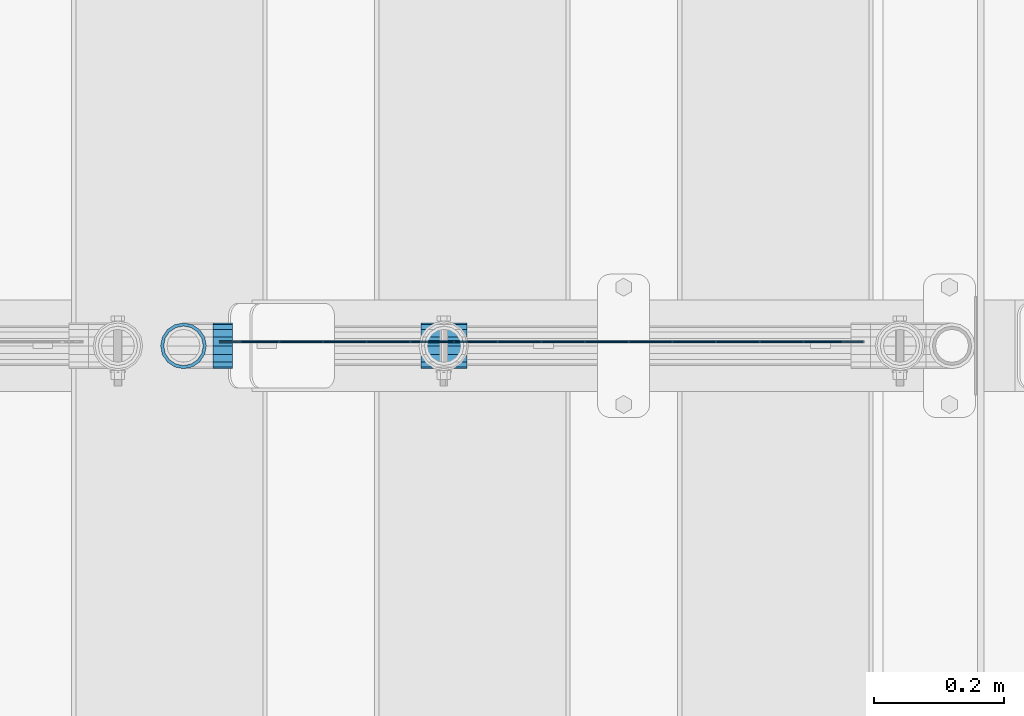
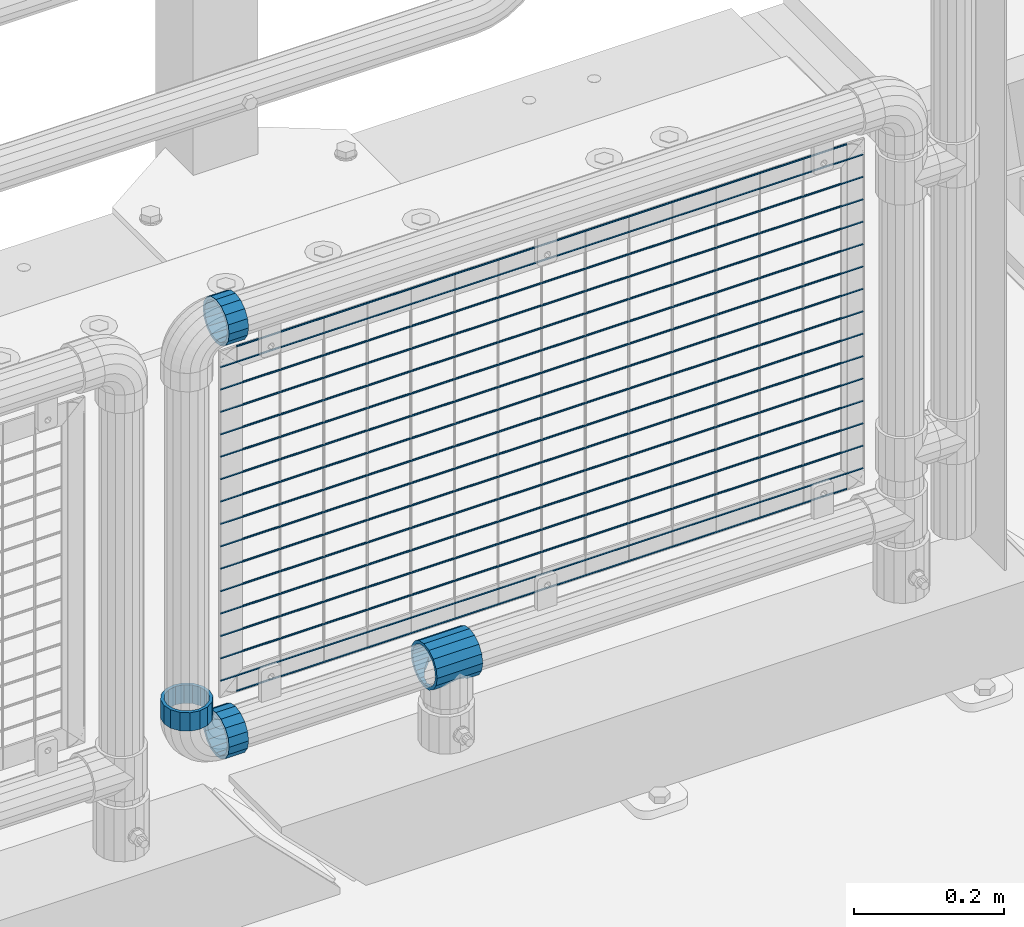
# One storey, part 169 of 257: 21 beams.
"""IFC2X3 building model written with IfcOpenShell, lengths in millimetres."""

from ifc_helpers import new_model, si_unit, frame, origin_with_axes, place, context, subcontext, project, spatial, faceted_brep, material, type_object, element, save


model = new_model("IFC2X3")

# Units and contexts
model_context = context("Model", 3, precision=1e-05, world=origin_with_axes())
body_context = subcontext(model_context, "Body", "Model", "MODEL_VIEW")
ifc_project = project(units=[si_unit("LENGTHUNIT", "METRE", prefix="MILLI"), si_unit("AREAUNIT", "SQUARE_METRE"), si_unit("VOLUMEUNIT", "CUBIC_METRE"), si_unit("MASSUNIT", "GRAM", prefix="KILO"), si_unit("TIMEUNIT", "SECOND"), si_unit("PLANEANGLEUNIT", "RADIAN"), si_unit("SOLIDANGLEUNIT", "STERADIAN"), si_unit("THERMODYNAMICTEMPERATUREUNIT", "DEGREE_CELSIUS"), si_unit("LUMINOUSINTENSITYUNIT", "LUMEN")], contexts=[model_context])

# Site, building, storey
site_placement = place(None, origin_with_axes())
site = spatial("IfcSite", under=ifc_project, at=site_placement, CompositionType="ELEMENT")
building_placement = place(site_placement, origin_with_axes())
building = spatial("IfcBuilding", under=site, at=building_placement, Name="Standard", CompositionType="ELEMENT")
storey_placement = place(building_placement, origin_with_axes())
storey = spatial("IfcBuildingStorey", under=building, at=storey_placement, Name="Undefined", CompositionType="ELEMENT", Elevation=0.0)

# Beams
ifc_material = material(Name="Misc_Undefined")
beam_type_1 = type_object("IfcBeamType", PredefinedType="NOTDEFINED")
beam_1_placement = place(storey_placement, frame((57936.46, 10664.5, 298.169999999999), z_axis=(0.0, 0.0, 1.0), x_axis=(1.0, 0.0, 0.0)))
element("IfcBeam", 1, at=beam_1_placement, inside=storey, type_object=beam_type_1, material=ifc_material, context=body_context, shape_type="Brep", body=[
    faceted_brep([(61.9623795176756, -13.4513226476338, -32.4743655677739), (56.6106908090114, -21.4606908090118, -27.1226768591077), (56.6106908090114, -21.4606908090118, -21.4606908090136), (63.1897438117172, -11.6144421722802, -28.0397438117143), (63.1897438117172, -11.6144421722802, -32.8397438117245), (51.5310424080038, -24.8548033587067, -24.8548033587067), (46.7644421722801, -28.0397438117179, -20.0882031229849), (46.7644421722801, -28.0397438117179, -11.6144421722784), (35.1499999999996, -30.3500000000004, -16.6306603983685), (35.1500000000015, -30.35, 0.0), (23.5355578277191, -28.0397438117179, -20.0882031229849), (23.5355578277191, -28.0397438117179, -11.6144421722784), (13.6893091909879, -21.4606908090118, -27.1226768591077), (13.6893091909879, -21.4606908090118, -21.4606908090136), (18.7689575919987, -24.8548033587067, -24.8548033587067), (7.11025618828205, -11.6144421722802, -32.8397438117245), (7.11025618828205, -11.6144421722802, -28.0397438117143), (8.33762048232484, -13.4513226476338, -32.4743655677739), (4.79999999999961, 0.0, -35.1500000000015), (4.79999999999961, 0.0, -30.3499999999985), (7.11025618828211, 11.6144421722802, -32.8397438117245), (7.11025618828211, 11.6144421722802, -28.0397438117143), (8.3376204823237, 13.4513226476338, -32.4743655677739), (13.6893091909879, 21.4606908090118, -27.1226768591077), (13.6893091909879, 21.4606908090118, -21.4606908090136), (18.7689575919954, 24.8548033587067, -24.8548033587067), (23.5355578277192, 28.0397438117179, -20.0882031229921), (23.5355578277192, 28.0397438117179, -11.6144421722784), (35.1499999999996, 30.3500000000004, -16.6306603983758), (35.1500000000015, 30.35, 0.0), (46.7644421722801, 28.0397438117179, -20.0882031229921), (46.7644421722801, 28.0397438117179, -11.6144421722784), (56.6106908090114, 21.4606908090118, -27.1226768591077), (56.6106908090114, 21.4606908090118, -21.4606908090136), (51.5310424080039, 24.8548033587067, -24.8548033587067), (63.1897438117172, 11.6144421722802, -32.8397438117245), (63.1897438117172, 11.6144421722802, -28.0397438117143), (61.9623795176756, 13.4513226476338, -32.4743655677739), (65.4999999999997, 0.0, -35.1500000000015), (65.4999999999997, 0.0, -30.3499999999985), (0.0, -21.4606908090118, -21.4606908090136), (0.0, -28.0397438117179, -11.6144421722784), (0.0, -11.6144421722802, -28.0397438117143), (0.0, 0.0, -30.3499999999985), (0.0, 11.6144421722802, -28.0397438117143), (0.0, 21.4606908090118, -21.4606908090136), (0.0, 28.0397438117179, -11.6144421722784), (0.0, 30.3500000000004, 0.0), (0.0, 32.4743655677721, -13.4513226476338), (0.0, 35.1499999999996, 0.0), (70.2999999999993, 35.1499999999996, 0.0), (70.2999999999993, 32.4743655677721, -13.4513226476338), (0.0, 32.4743655677721, 13.4513226476338), (70.2999999999993, 32.4743655677721, 13.4513226476338), (0.0, 24.8548033587067, 24.8548033587067), (70.2999999999993, 24.8548033587067, 24.8548033587067), (0.0, 13.4513226476338, 32.4743655677739), (70.2999999999993, 13.4513226476338, 32.4743655677739), (0.0, 0.0, 35.1499999999996), (70.2999999999993, 0.0, 35.1500000000015), (0.0, -13.4513226476338, 32.4743655677739), (70.2999999999993, -13.4513226476338, 32.4743655677739), (0.0, -24.8548033587067, 24.8548033587067), (70.2999999999993, -24.8548033587067, 24.8548033587067), (0.0, -32.4743655677721, 13.4513226476338), (70.2999999999993, -32.4743655677721, 13.4513226476338), (0.0, -35.1499999999996, 0.0), (70.2999999999993, -35.1499999999996, 0.0), (0.0, -32.4743655677721, -13.4513226476338), (70.2999999999993, -32.4743655677721, -13.4513226476338), (0.0, 24.8548033587067, -24.8548033587067), (0.0, 13.4513226476338, -32.4743655677739), (0.0, 0.0, -35.1499999999996), (0.0, -13.4513226476338, -32.4743655677739), (0.0, -24.8548033587067, -24.8548033587067), (0.0, 28.0397438117179, 11.6144421722784), (0.0, 21.4606908090118, 21.4606908090136), (0.0, 11.6144421722802, 28.0397438117143), (0.0, 0.0, 30.3499999999985), (0.0, -11.6144421722802, 28.0397438117143), (0.0, -21.4606908090118, 21.4606908090136), (0.0, -28.0397438117179, 11.6144421722784), (0.0, -30.3500000000004, 0.0), (70.2999999999993, -30.3500000000004, 0.0), (70.2999999999993, -28.0397438117179, -11.6144421722784), (70.2999999999993, -21.4606908090118, -21.4606908090136), (70.2999999999993, -11.6144421722802, -28.0397438117143), (70.2999999999993, 0.0, -30.3499999999985), (70.2999999999993, 21.4606908090118, -21.4606908090136), (70.2999999999993, 28.0397438117179, -11.6144421722784), (70.2999999999993, 11.6144421722802, -28.0397438117143), (70.2999999999993, 30.3500000000004, 0.0), (70.2999999999993, 28.0397438117179, 11.6144421722784), (70.2999999999993, 21.4606908090118, 21.4606908090136), (70.2999999999993, 11.6144421722802, 28.0397438117143), (70.2999999999993, 0.0, 30.3499999999985), (70.2999999999993, -11.6144421722802, 28.0397438117143), (70.2999999999993, -21.4606908090118, 21.4606908090136), (70.2999999999993, -28.0397438117179, 11.6144421722784), (70.2999999999993, -24.8548033587067, -24.8548033587067), (70.2999999999993, -13.4513226476338, -32.4743655677739), (70.2999999999993, 0.0, -35.1500000000015), (70.2999999999993, 13.4513226476338, -32.4743655677739), (70.2999999999993, 24.8548033587067, -24.8548033587067)], [[[0, 1, 2, 3, 4]], [[5, 6, 7, 2, 1]], [[8, 9, 7, 6]], [[10, 11, 9, 8]], [[12, 13, 11, 10, 14]], [[15, 16, 13, 12, 17]], [[18, 19, 16, 15]], [[20, 21, 19, 18]], [[22, 23, 24, 21, 20]], [[25, 26, 27, 24, 23]], [[28, 29, 27, 26]], [[30, 31, 29, 28]], [[32, 33, 31, 30, 34]], [[35, 36, 33, 32, 37]], [[38, 39, 36, 35]], [[4, 3, 39, 38]], [[40, 41, 11, 13]], [[42, 40, 13, 16]], [[43, 42, 16, 19]], [[44, 43, 19, 21]], [[45, 44, 21, 24]], [[46, 45, 24, 27]], [[47, 46, 27, 29]], [[48, 49, 50, 51]], [[49, 52, 53, 50]], [[52, 54, 55, 53]], [[54, 56, 57, 55]], [[56, 58, 59, 57]], [[58, 60, 61, 59]], [[60, 62, 63, 61]], [[62, 64, 65, 63]], [[64, 66, 67, 65]], [[66, 68, 69, 67]], [[64, 62, 60, 58, 56, 54, 52, 49, 48, 70, 71, 72, 73, 74, 68, 66], [41, 40, 42, 43, 44, 45, 46, 47, 75, 76, 77, 78, 79, 80, 81, 82]], [[41, 82, 9, 11]], [[83, 84, 7, 9]], [[84, 85, 2, 7]], [[85, 86, 3, 2]], [[86, 87, 39, 3]], [[88, 89, 31, 33]], [[90, 88, 33, 36]], [[87, 90, 36, 39]], [[89, 91, 29, 31]], [[75, 47, 29, 91, 92]], [[76, 75, 92, 93]], [[77, 76, 93, 94]], [[78, 77, 94, 95]], [[79, 78, 95, 96]], [[80, 79, 96, 97]], [[81, 80, 97, 98]], [[9, 82, 81, 98, 83]], [[99, 100, 101, 102, 103, 51, 50, 53, 55, 57, 59, 61, 63, 65, 67, 69], [97, 96, 95, 94, 93, 92, 91, 89, 88, 90, 87, 86, 85, 84, 83, 98]], [[37, 102, 101, 38, 35]], [[34, 103, 102, 37, 32]], [[28, 26, 25, 70, 48, 51, 103, 34, 30]], [[71, 70, 25, 23, 22]], [[72, 71, 22, 20, 18]], [[17, 73, 72, 18, 15]], [[14, 74, 73, 17, 12]], [[99, 69, 68, 74, 14, 10, 8, 6, 5]], [[100, 99, 5, 1, 0]], [[101, 100, 0, 4, 38]]]),
])
beam_2_placement = place(storey_placement, frame((57616.61, 10664.5, 298.170000000001), z_axis=(0.0, 0.0, -1.0), x_axis=(1.0, 0.0, 0.0)))
element("IfcBeam", 2, at=beam_2_placement, inside=storey, type_object=beam_type_1, material=ifc_material, context=body_context, shape_type="Brep", body=[
    faceted_brep([(0.0, -30.3500000000004, 0.0), (0.0, -28.0397438117179, 11.6144421722784), (30.0, -28.0397438117179, 11.6144421722805), (30.0, -30.3500000000004, 0.0), (0.0, -21.4606908090118, 21.4606908090136), (30.0, -21.4606908090118, 21.4606908090117), (0.0, -11.6144421722802, 28.0397438117143), (30.0, -11.6144421722802, 28.0397438117175), (0.0, 0.0, 30.3499999999985), (30.0, 0.0, 30.35), (0.0, 11.6144421722802, 28.0397438117143), (30.0, 11.6144421722802, 28.0397438117175), (0.0, 21.4606908090118, 21.4606908090136), (30.0, 21.4606908090118, 21.4606908090117), (0.0, 28.0397438117179, 11.6144421722784), (30.0, 28.0397438117179, 11.6144421722805), (0.0, 30.3500000000004, 0.0), (30.0, 30.3500000000004, 0.0), (0.0, 28.0397438117179, -11.6144421722784), (30.0, 28.0397438117179, -11.6144421722805), (0.0, 21.4606908090118, -21.4606908090136), (30.0, 21.4606908090118, -21.4606908090117), (0.0, 11.6144421722802, -28.0397438117143), (30.0, 11.6144421722802, -28.0397438117175), (0.0, 0.0, -30.3499999999985), (30.0, 0.0, -30.35), (0.0, -11.6144421722802, -28.0397438117143), (30.0, -11.6144421722802, -28.0397438117175), (0.0, -21.4606908090118, -21.4606908090136), (30.0, -21.4606908090118, -21.4606908090117), (0.0, -28.0397438117179, -11.6144421722784), (30.0, -28.0397438117179, -11.6144421722805), (0.0, -35.1499999999996, 0.0), (0.0, -32.4743655677721, -13.4513226476338), (30.0, -32.4743655677721, -13.4513226476329), (30.0, -35.1499999999996, 0.0), (0.0, -24.8548033587067, -24.8548033587067), (30.0, -24.8548033587067, -24.8548033587072), (0.0, -13.4513226476338, -32.4743655677739), (30.0, -13.4513226476338, -32.4743655677717), (0.0, 0.0, -35.1499999999996), (30.0, 0.0, -35.15), (0.0, 13.4513226476338, -32.4743655677739), (30.0, 13.4513226476338, -32.4743655677717), (0.0, 24.8548033587067, -24.8548033587067), (30.0, 24.8548033587067, -24.8548033587072), (0.0, 32.4743655677721, -13.4513226476338), (30.0, 32.4743655677721, -13.4513226476329), (0.0, 35.1499999999996, 0.0), (30.0, 35.1499999999996, 0.0), (0.0, 32.4743655677721, 13.4513226476338), (30.0, 32.4743655677721, 13.4513226476329), (0.0, 24.8548033587067, 24.8548033587067), (30.0, 24.8548033587067, 24.8548033587072), (0.0, 13.4513226476338, 32.4743655677739), (30.0, 13.4513226476338, 32.4743655677717), (0.0, 0.0, 35.1499999999996), (30.0, 0.0, 35.15), (0.0, -13.4513226476338, 32.4743655677739), (30.0, -13.4513226476338, 32.4743655677717), (0.0, -24.8548033587067, 24.8548033587067), (30.0, -24.8548033587067, 24.8548033587072), (0.0, -32.4743655677721, 13.4513226476338), (30.0, -32.4743655677721, 13.4513226476329)], [[[0, 1, 2, 3]], [[1, 4, 5, 2]], [[4, 6, 7, 5]], [[6, 8, 9, 7]], [[8, 10, 11, 9]], [[10, 12, 13, 11]], [[12, 14, 15, 13]], [[14, 16, 17, 15]], [[16, 18, 19, 17]], [[18, 20, 21, 19]], [[20, 22, 23, 21]], [[22, 24, 25, 23]], [[24, 26, 27, 25]], [[26, 28, 29, 27]], [[28, 30, 31, 29]], [[30, 0, 3, 31]], [[32, 33, 34, 35]], [[33, 36, 37, 34]], [[36, 38, 39, 37]], [[38, 40, 41, 39]], [[40, 42, 43, 41]], [[42, 44, 45, 43]], [[44, 46, 47, 45]], [[46, 48, 49, 47]], [[48, 50, 51, 49]], [[50, 52, 53, 51]], [[52, 54, 55, 53]], [[54, 56, 57, 55]], [[56, 58, 59, 57]], [[58, 60, 61, 59]], [[60, 62, 63, 61]], [[62, 32, 35, 63]], [[37, 39, 41, 43, 45, 47, 49, 51, 53, 55, 57, 59, 61, 63, 35, 34], [5, 7, 9, 11, 13, 15, 17, 19, 21, 23, 25, 27, 29, 31, 3, 2]], [[62, 60, 58, 56, 54, 52, 50, 48, 46, 44, 42, 40, 38, 36, 33, 32], [30, 28, 26, 24, 22, 20, 18, 16, 14, 12, 10, 8, 6, 4, 1, 0]]]),
])
beam_3_placement = place(storey_placement, frame((57571.61, 10664.5, 373.170000000002), z_axis=(-1.0, 0.0, 0.0), x_axis=(0.0, 0.0, -1.0)))
element("IfcBeam", 3, at=beam_3_placement, inside=storey, type_object=beam_type_1, material=ifc_material, context=body_context, shape_type="Brep", body=[
    faceted_brep([(0.0, -30.3500000000004, 0.0), (0.0, -28.0397438117179, 11.6144421722784), (30.0, -28.0397438117179, 11.6144421722805), (30.0, -30.3500000000004, 0.0), (0.0, -21.4606908090118, 21.4606908090136), (30.0, -21.4606908090118, 21.4606908090117), (0.0, -11.6144421722802, 28.0397438117143), (30.0, -11.6144421722802, 28.0397438117175), (0.0, 0.0, 30.3499999999985), (30.0, 0.0, 30.35), (0.0, 11.6144421722802, 28.0397438117143), (30.0, 11.6144421722802, 28.0397438117175), (0.0, 21.4606908090118, 21.4606908090136), (30.0, 21.4606908090118, 21.4606908090117), (0.0, 28.0397438117179, 11.6144421722784), (30.0, 28.0397438117179, 11.6144421722805), (0.0, 30.3500000000004, 0.0), (30.0, 30.3500000000004, 0.0), (0.0, 28.0397438117179, -11.6144421722784), (30.0, 28.0397438117179, -11.6144421722805), (0.0, 21.4606908090118, -21.4606908090136), (30.0, 21.4606908090118, -21.4606908090117), (0.0, 11.6144421722802, -28.0397438117143), (30.0, 11.6144421722802, -28.0397438117175), (0.0, 0.0, -30.3499999999985), (30.0, 0.0, -30.35), (0.0, -11.6144421722802, -28.0397438117143), (30.0, -11.6144421722802, -28.0397438117175), (0.0, -21.4606908090118, -21.4606908090136), (30.0, -21.4606908090118, -21.4606908090117), (0.0, -28.0397438117179, -11.6144421722784), (30.0, -28.0397438117179, -11.6144421722805), (0.0, -35.1499999999996, 0.0), (0.0, -32.4743655677721, -13.4513226476338), (30.0, -32.4743655677721, -13.4513226476329), (30.0, -35.1499999999996, 0.0), (0.0, -24.8548033587067, -24.8548033587067), (30.0, -24.8548033587067, -24.8548033587072), (0.0, -13.4513226476338, -32.4743655677739), (30.0, -13.4513226476338, -32.4743655677717), (0.0, 0.0, -35.1499999999996), (30.0, 0.0, -35.15), (0.0, 13.4513226476338, -32.4743655677739), (30.0, 13.4513226476338, -32.4743655677717), (0.0, 24.8548033587067, -24.8548033587067), (30.0, 24.8548033587067, -24.8548033587072), (0.0, 32.4743655677721, -13.4513226476338), (30.0, 32.4743655677721, -13.4513226476329), (0.0, 35.1499999999996, 0.0), (30.0, 35.1499999999996, 0.0), (0.0, 32.4743655677721, 13.4513226476338), (30.0, 32.4743655677721, 13.4513226476329), (0.0, 24.8548033587067, 24.8548033587067), (30.0, 24.8548033587067, 24.8548033587072), (0.0, 13.4513226476338, 32.4743655677739), (30.0, 13.4513226476338, 32.4743655677717), (0.0, 0.0, 35.1499999999996), (30.0, 0.0, 35.15), (0.0, -13.4513226476338, 32.4743655677739), (30.0, -13.4513226476338, 32.4743655677717), (0.0, -24.8548033587067, 24.8548033587067), (30.0, -24.8548033587067, 24.8548033587072), (0.0, -32.4743655677721, 13.4513226476338), (30.0, -32.4743655677721, 13.4513226476329)], [[[0, 1, 2, 3]], [[1, 4, 5, 2]], [[4, 6, 7, 5]], [[6, 8, 9, 7]], [[8, 10, 11, 9]], [[10, 12, 13, 11]], [[12, 14, 15, 13]], [[14, 16, 17, 15]], [[16, 18, 19, 17]], [[18, 20, 21, 19]], [[20, 22, 23, 21]], [[22, 24, 25, 23]], [[24, 26, 27, 25]], [[26, 28, 29, 27]], [[28, 30, 31, 29]], [[30, 0, 3, 31]], [[32, 33, 34, 35]], [[33, 36, 37, 34]], [[36, 38, 39, 37]], [[38, 40, 41, 39]], [[40, 42, 43, 41]], [[42, 44, 45, 43]], [[44, 46, 47, 45]], [[46, 48, 49, 47]], [[48, 50, 51, 49]], [[50, 52, 53, 51]], [[52, 54, 55, 53]], [[54, 56, 57, 55]], [[56, 58, 59, 57]], [[58, 60, 61, 59]], [[60, 62, 63, 61]], [[62, 32, 35, 63]], [[37, 39, 41, 43, 45, 47, 49, 51, 53, 55, 57, 59, 61, 63, 35, 34], [5, 7, 9, 11, 13, 15, 17, 19, 21, 23, 25, 27, 29, 31, 3, 2]], [[62, 60, 58, 56, 54, 52, 50, 48, 46, 44, 42, 40, 38, 36, 33, 32], [30, 28, 26, 24, 22, 20, 18, 16, 14, 12, 10, 8, 6, 4, 1, 0]]]),
])
beam_4_placement = place(storey_placement, frame((57616.61, 10664.5, 969.849999999999), z_axis=(0.0, 0.0, 1.0), x_axis=(1.0, 0.0, 0.0)))
element("IfcBeam", 4, at=beam_4_placement, inside=storey, type_object=beam_type_1, material=ifc_material, context=body_context, shape_type="Brep", body=[
    faceted_brep([(0.0, -30.3500000000004, 0.0), (0.0, -28.0397438117179, 11.6144421722784), (30.0, -28.0397438117179, 11.6144421722805), (30.0, -30.3500000000004, 0.0), (0.0, -21.4606908090118, 21.4606908090136), (30.0, -21.4606908090118, 21.4606908090117), (0.0, -11.6144421722802, 28.0397438117143), (30.0, -11.6144421722802, 28.0397438117175), (0.0, 0.0, 30.3499999999985), (30.0, 0.0, 30.35), (0.0, 11.6144421722802, 28.0397438117143), (30.0, 11.6144421722802, 28.0397438117175), (0.0, 21.4606908090118, 21.4606908090136), (30.0, 21.4606908090118, 21.4606908090117), (0.0, 28.0397438117179, 11.6144421722784), (30.0, 28.0397438117179, 11.6144421722805), (0.0, 30.3500000000004, 0.0), (30.0, 30.3500000000004, 0.0), (0.0, 28.0397438117179, -11.6144421722784), (30.0, 28.0397438117179, -11.6144421722805), (0.0, 21.4606908090118, -21.4606908090136), (30.0, 21.4606908090118, -21.4606908090117), (0.0, 11.6144421722802, -28.0397438117143), (30.0, 11.6144421722802, -28.0397438117175), (0.0, 0.0, -30.3499999999985), (30.0, 0.0, -30.35), (0.0, -11.6144421722802, -28.0397438117143), (30.0, -11.6144421722802, -28.0397438117175), (0.0, -21.4606908090118, -21.4606908090136), (30.0, -21.4606908090118, -21.4606908090117), (0.0, -28.0397438117179, -11.6144421722784), (30.0, -28.0397438117179, -11.6144421722805), (0.0, -35.1499999999996, 0.0), (0.0, -32.4743655677721, -13.4513226476338), (30.0, -32.4743655677721, -13.4513226476329), (30.0, -35.1499999999996, 0.0), (0.0, -24.8548033587067, -24.8548033587067), (30.0, -24.8548033587067, -24.8548033587072), (0.0, -13.4513226476338, -32.4743655677739), (30.0, -13.4513226476338, -32.4743655677717), (0.0, 0.0, -35.1499999999996), (30.0, 0.0, -35.15), (0.0, 13.4513226476338, -32.4743655677739), (30.0, 13.4513226476338, -32.4743655677717), (0.0, 24.8548033587067, -24.8548033587067), (30.0, 24.8548033587067, -24.8548033587072), (0.0, 32.4743655677721, -13.4513226476338), (30.0, 32.4743655677721, -13.4513226476329), (0.0, 35.1499999999996, 0.0), (30.0, 35.1499999999996, 0.0), (0.0, 32.4743655677721, 13.4513226476338), (30.0, 32.4743655677721, 13.4513226476329), (0.0, 24.8548033587067, 24.8548033587067), (30.0, 24.8548033587067, 24.8548033587072), (0.0, 13.4513226476338, 32.4743655677739), (30.0, 13.4513226476338, 32.4743655677717), (0.0, 0.0, 35.1499999999996), (30.0, 0.0, 35.15), (0.0, -13.4513226476338, 32.4743655677739), (30.0, -13.4513226476338, 32.4743655677717), (0.0, -24.8548033587067, 24.8548033587067), (30.0, -24.8548033587067, 24.8548033587072), (0.0, -32.4743655677721, 13.4513226476338), (30.0, -32.4743655677721, 13.4513226476329)], [[[0, 1, 2, 3]], [[1, 4, 5, 2]], [[4, 6, 7, 5]], [[6, 8, 9, 7]], [[8, 10, 11, 9]], [[10, 12, 13, 11]], [[12, 14, 15, 13]], [[14, 16, 17, 15]], [[16, 18, 19, 17]], [[18, 20, 21, 19]], [[20, 22, 23, 21]], [[22, 24, 25, 23]], [[24, 26, 27, 25]], [[26, 28, 29, 27]], [[28, 30, 31, 29]], [[30, 0, 3, 31]], [[32, 33, 34, 35]], [[33, 36, 37, 34]], [[36, 38, 39, 37]], [[38, 40, 41, 39]], [[40, 42, 43, 41]], [[42, 44, 45, 43]], [[44, 46, 47, 45]], [[46, 48, 49, 47]], [[48, 50, 51, 49]], [[50, 52, 53, 51]], [[52, 54, 55, 53]], [[54, 56, 57, 55]], [[56, 58, 59, 57]], [[58, 60, 61, 59]], [[60, 62, 63, 61]], [[62, 32, 35, 63]], [[37, 39, 41, 43, 45, 47, 49, 51, 53, 55, 57, 59, 61, 63, 35, 34], [5, 7, 9, 11, 13, 15, 17, 19, 21, 23, 25, 27, 29, 31, 3, 2]], [[62, 60, 58, 56, 54, 52, 50, 48, 46, 44, 42, 40, 38, 36, 33, 32], [30, 28, 26, 24, 22, 20, 18, 16, 14, 12, 10, 8, 6, 4, 1, 0]]]),
])
beam_type_2 = type_object("IfcBeamType", Name="D3", PredefinedType="NOTDEFINED")
for number, where, z_axis, x_axis in (
    (5, (57626.61, 10670.4999883346, 633.023), (0.0, 0.0, 1.0), (1.0, 0.0, 0.0)),
    (6, (57626.61, 10670.4999883385, 815.168), (0.0, 0.0, 1.0), (1.0, 0.0, 0.0)),
    (7, (57626.61, 10670.4999883354, 669.452), (0.0, 0.0, 1.0), (1.0, 0.0, 0.0)),
    (8, (57626.61, 10670.4999883338, 596.594000000001), (0.0, 0.0, 1.0), (1.0, 0.0, 0.0)),
    (9, (57626.61, 10670.4999883331, 560.165), (0.0, 0.0, 1.0), (1.0, 0.0, 0.0)),
    (10, (57626.61, 10670.4999883377, 778.739), (0.0, 0.0, 1.0), (1.0, 0.0, 0.0)),
    (11, (57626.61, 10670.4999883323, 523.736), (0.0, 0.0, 1.0), (1.0, 0.0, 0.0)),
    (12, (57626.61, 10670.4999883392, 851.597), (0.0, 0.0, 1.0), (1.0, 0.0, 0.0)),
    (13, (57626.61, 10670.4999883315, 487.307), (0.0, 0.0, 1.0), (1.0, 0.0, 0.0)),
    (14, (57626.61, 10670.4999883361, 705.881), (0.0, 0.0, 1.0), (1.0, 0.0, 0.0)),
    (15, (57626.61, 10670.4999883308, 450.878), (0.0, 0.0, 1.0), (1.0, 0.0, 0.0)),
    (16, (57626.61, 10670.49998834, 888.026), (0.0, 0.0, 1.0), (1.0, 0.0, 0.0)),
    (17, (57626.61, 10670.4999883369, 742.31), (0.0, 0.0, 1.0), (1.0, 0.0, 0.0)),
    (18, (57626.61, 10670.49998833, 414.449), (0.0, 0.0, 1.0), (1.0, 0.0, 0.0)),
):
    element("IfcBeam", number, at=place(storey_placement, frame(where, z_axis=z_axis, x_axis=x_axis)), inside=storey, type_object=beam_type_2, material=ifc_material, ObjectType="D3", context=body_context, shape_type="Brep", body=[
        faceted_brep([(0.0, -1.5, -5.6843418860808e-14), (0.0, -0.750000000001819, -1.29903810567669), (988.39000000024, -0.750000000001819, -1.29903810567669), (988.39000000024, -1.50000000000182, 0.0), (7.27595761418343e-12, 0.749999999998181, -1.29903810567669), (988.390000000247, 0.749999999998181, -1.29903810567669), (0.0, 1.5, -5.6843418860808e-14), (988.390000000247, 1.49999999999818, 0.0), (7.27595761418343e-12, 0.749999999998181, 1.29903810567669), (988.390000000247, 0.749999999998181, 1.29903810567669), (0.0, -0.750000000001819, 1.29903810567669), (988.39000000024, -0.750000000001819, 1.29903810567669)], [[[0, 1, 2, 3]], [[1, 4, 5, 2]], [[4, 6, 7, 5]], [[6, 8, 9, 7]], [[8, 10, 11, 9]], [[10, 0, 3, 11]], [[5, 7, 9, 11, 3, 2]], [[10, 8, 6, 4, 1, 0]]]),
    ])
beam_5_placement = place(storey_placement, frame((57651.61, 10670.4999830243, 353.02), z_axis=(0.0, 0.0, 1.0), x_axis=(1.0, 0.0, 0.0)))
element("IfcBeam", 19, at=beam_5_placement, inside=storey, type_object=beam_type_2, material=ifc_material, ObjectType="D3", context=body_context, shape_type="Brep", body=[
    faceted_brep([(0.0, -1.5, -5.6843418860808e-14), (0.0, -0.750000000001819, -1.29903810567669), (938.390000000094, -0.75, -1.29903810567669), (938.390000000094, -1.5, 0.0), (7.27595761418343e-12, 0.749999999998181, -1.29903810567669), (938.390000000094, 0.75, -1.29903810567663), (0.0, 1.5, -5.6843418860808e-14), (938.390000000101, 1.5, 0.0), (7.27595761418343e-12, 0.749999999998181, 1.29903810567669), (938.390000000094, 0.75, 1.29903810567669), (0.0, -0.750000000001819, 1.29903810567669), (938.390000000094, -0.75, 1.29903810567669)], [[[0, 1, 2, 3]], [[1, 4, 5, 2]], [[4, 6, 7, 5]], [[6, 8, 9, 7]], [[8, 10, 11, 9]], [[10, 0, 3, 11]], [[5, 7, 9, 11, 3, 2]], [[10, 8, 6, 4, 1, 0]]]),
])
beam_6_placement = place(storey_placement, frame((57626.61, 10670.4999883292, 378.02), z_axis=(0.0, 0.0, 1.0), x_axis=(1.0, 0.0, 0.0)))
element("IfcBeam", 20, at=beam_6_placement, inside=storey, type_object=beam_type_2, material=ifc_material, ObjectType="D3", context=body_context, shape_type="Brep", body=[
    faceted_brep([(0.0, -1.5, -5.6843418860808e-14), (0.0, -0.750000000001819, -1.29903810567669), (988.39000000024, -0.750000000001819, -1.29903810567669), (988.39000000024, -1.50000000000182, 0.0), (7.27595761418343e-12, 0.749999999998181, -1.29903810567669), (988.390000000247, 0.749999999998181, -1.29903810567669), (0.0, 1.5, -5.6843418860808e-14), (988.390000000247, 1.49999999999818, 0.0), (7.27595761418343e-12, 0.749999999998181, 1.29903810567669), (988.390000000247, 0.749999999998181, 1.29903810567669), (0.0, -0.750000000001819, 1.29903810567669), (988.39000000024, -0.750000000001819, 1.29903810567669)], [[[0, 1, 2, 3]], [[1, 4, 5, 2]], [[4, 6, 7, 5]], [[6, 8, 9, 7]], [[8, 10, 11, 9]], [[10, 0, 3, 11]], [[5, 7, 9, 11, 3, 2]], [[10, 8, 6, 4, 1, 0]]]),
])
beam_7_placement = place(storey_placement, frame((57651.61, 10670.49998304, 913.02), z_axis=(0.0, 0.0, 1.0), x_axis=(1.0, 0.0, 0.0)))
element("IfcBeam", 21, at=beam_7_placement, inside=storey, type_object=beam_type_2, material=ifc_material, ObjectType="D3", context=body_context, shape_type="Brep", body=[
    faceted_brep([(0.0, -1.5, -5.6843418860808e-14), (0.0, -0.750000000001819, -1.29903810567669), (938.390000000094, -0.75, -1.29903810567669), (938.390000000094, -1.5, 0.0), (7.27595761418343e-12, 0.749999999998181, -1.29903810567669), (938.390000000094, 0.75, -1.29903810567663), (0.0, 1.5, -5.6843418860808e-14), (938.390000000101, 1.5, 0.0), (7.27595761418343e-12, 0.749999999998181, 1.29903810567669), (938.390000000094, 0.75, 1.29903810567669), (0.0, -0.750000000001819, 1.29903810567669), (938.390000000094, -0.75, 1.29903810567669)], [[[0, 1, 2, 3]], [[1, 4, 5, 2]], [[4, 6, 7, 5]], [[6, 8, 9, 7]], [[8, 10, 11, 9]], [[10, 0, 3, 11]], [[5, 7, 9, 11, 3, 2]], [[10, 8, 6, 4, 1, 0]]]),
])

save(model, "model.ifc")
